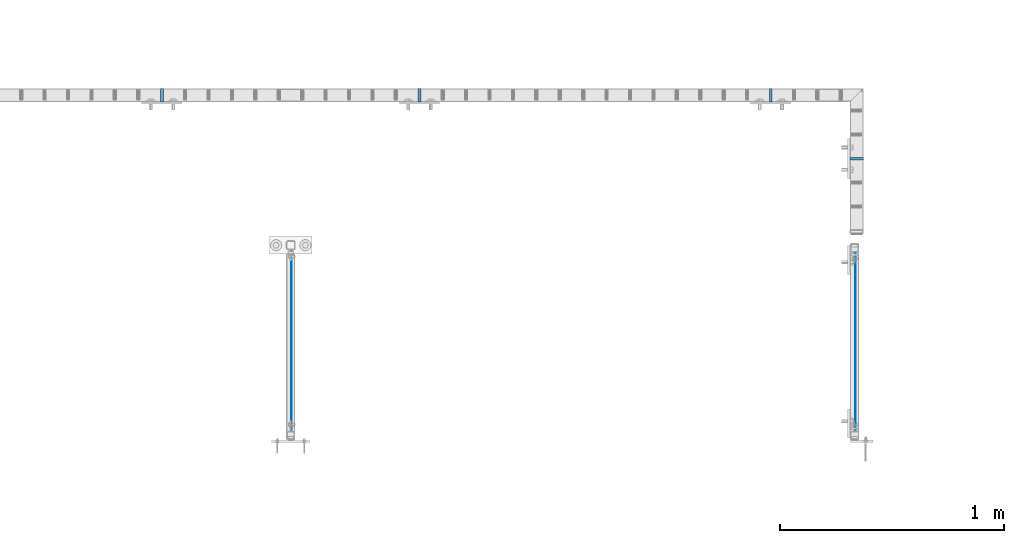
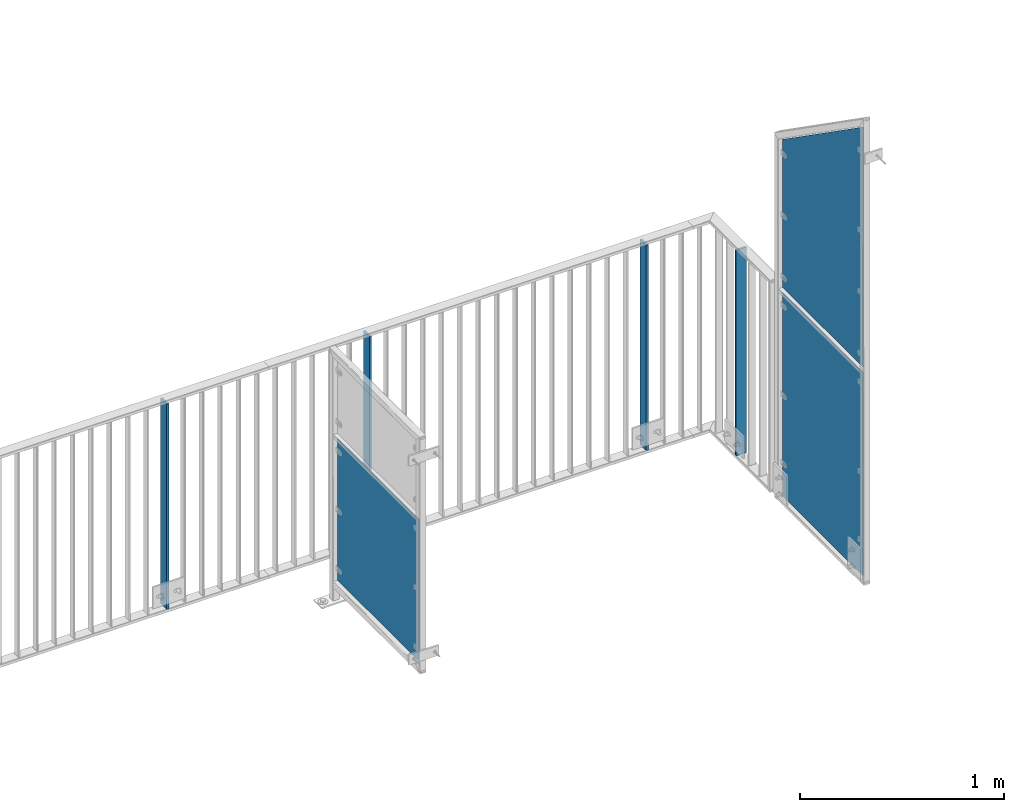
# One storey, part 45 of 156: 7 plates, 6 elements without a shape of their own.
"""IFC2X3 building model written with IfcOpenShell, lengths in millimetres."""

from ifc_helpers import new_model, si_unit, frame, origin_with_axes, origin_2d_with_axis, place, context, subcontext, project, spatial, rectangle, extrude, clip, halfspace, material, type_object, element, aggregate, save


model = new_model("IFC2X3")

# Units and contexts
model_context = context("Model", 3, precision=1e-05, world=origin_with_axes())
body_context = subcontext(model_context, "Body", "Model", "MODEL_VIEW")
ifc_project = project(units=[si_unit("LENGTHUNIT", "METRE", prefix="MILLI"), si_unit("AREAUNIT", "SQUARE_METRE"), si_unit("VOLUMEUNIT", "CUBIC_METRE"), si_unit("MASSUNIT", "GRAM", prefix="KILO"), si_unit("TIMEUNIT", "SECOND"), si_unit("PLANEANGLEUNIT", "RADIAN"), si_unit("SOLIDANGLEUNIT", "STERADIAN"), si_unit("THERMODYNAMICTEMPERATUREUNIT", "DEGREE_CELSIUS"), si_unit("LUMINOUSINTENSITYUNIT", "LUMEN")], contexts=[model_context])

# Site, building, storey
site_placement = place(None, origin_with_axes())
site = spatial("IfcSite", under=ifc_project, at=site_placement, CompositionType="ELEMENT")
building_placement = place(site_placement, origin_with_axes())
building = spatial("IfcBuilding", under=site, at=building_placement, Name="Undefined", CompositionType="ELEMENT")
storey_placement = place(building_placement, origin_with_axes())
storey = spatial("IfcBuildingStorey", under=building, at=storey_placement, Name="Undefined", CompositionType="ELEMENT", Elevation=0.0)

# Assembly, plate
assembly_1_placement = place(storey_placement, origin_with_axes())
assembly_1 = element("IfcElementAssembly", 1, at=assembly_1_placement, inside=storey, AssemblyPlace="NOTDEFINED", PredefinedType="RIGID_FRAME")
ifc_material = material(Name="STEEL/S235JR")
plate_type_1 = type_object("IfcPlateType", PredefinedType="NOTDEFINED")
plate_1_placement = place(assembly_1_placement, frame((34574.6454415188, 21657.9919875293, 3980.00000000003), z_axis=(0.0, -1.0, 0.0), x_axis=(0.0, 0.0, -1.0)))
plate_1 = element("IfcPlate", 2, at=plate_1_placement, type_object=plate_type_1, material=ifc_material, context=body_context, shape_type="SweptSolid", body=[
    extrude(rectangle(XDim=12.0, YDim=60.0, at=origin_2d_with_axis()), frame((1230.0, 0.0, 0.0), z_axis=(-1.0, 0.0, 0.0), x_axis=(0.0, -1.0, 0.0)), (0.0, 0.0, 1.0), 1230.0),
])

assembly_2_placement = place(storey_placement, origin_with_axes())
assembly_2 = element("IfcElementAssembly", 3, at=assembly_2_placement, inside=storey, AssemblyPlace="NOTDEFINED", PredefinedType="RIGID_FRAME")
plate_2_placement = place(assembly_2_placement, frame((33425.3401831972, 21657.9919875293, 3980.00000000003), z_axis=(0.0, -1.0, 0.0), x_axis=(0.0, 0.0, -1.0)))
plate_2 = element("IfcPlate", 4, at=plate_2_placement, type_object=plate_type_1, material=ifc_material, context=body_context, shape_type="SweptSolid", body=[
    extrude(rectangle(XDim=12.0, YDim=60.0, at=origin_2d_with_axis()), frame((1230.0, 0.0, 0.0), z_axis=(-1.0, 0.0, 0.0), x_axis=(0.0, -1.0, 0.0)), (0.0, 0.0, 1.0), 1230.0),
])
aggregate(assembly_2, [plate_2])

assembly_3_placement = place(storey_placement, origin_with_axes())
assembly_3 = element("IfcElementAssembly", 5, at=assembly_3_placement, inside=storey, AssemblyPlace="NOTDEFINED", PredefinedType="RIGID_FRAME")
plate_3_placement = place(assembly_3_placement, frame((36524.9982838167, 21374.1507649875, 3980.00000000003), z_axis=(-1.0, 0.0, 0.0), x_axis=(0.0, 0.0, -1.0)))
plate_3 = element("IfcPlate", 6, at=plate_3_placement, type_object=plate_type_1, material=ifc_material, context=body_context, shape_type="SweptSolid", body=[
    extrude(rectangle(XDim=12.0, YDim=60.0, at=origin_2d_with_axis()), frame((1230.0, 0.0, 0.0), z_axis=(-1.0, 0.0, 0.0), x_axis=(0.0, -1.0, 0.0)), (0.0, 0.0, 1.0), 1230.0),
])
aggregate(assembly_3, [plate_3])

# Plate
plate_4_placement = place(assembly_1_placement, frame((36141.6668934283, 21657.9919875293, 3980.00000000003), z_axis=(0.0, -1.0, 0.0), x_axis=(0.0, 0.0, -1.0)))
plate_4 = element("IfcPlate", 7, at=plate_4_placement, type_object=plate_type_1, material=ifc_material, context=body_context, shape_type="SweptSolid", body=[
    extrude(rectangle(XDim=12.0, YDim=60.0, at=origin_2d_with_axis()), frame((1230.0, 0.0, 0.0), z_axis=(-1.0, 0.0, 0.0), x_axis=(0.0, -1.0, 0.0)), (0.0, 0.0, 1.0), 1230.0),
])

aggregate(assembly_1, [plate_1, plate_4])

# Assembly, plate
assembly_4_placement = place(storey_placement, origin_with_axes())
assembly_4 = element("IfcElementAssembly", 8, at=assembly_4_placement, inside=storey, AssemblyPlace="NOTDEFINED", PredefinedType="RIGID_FRAME")
plate_type_2 = type_object("IfcPlateType", PredefinedType="NOTDEFINED")
plate_5_placement = place(assembly_4_placement, frame((34004.0, 20162.9563390375, 3550.0), z_axis=(0.0, 0.0, 1.0), x_axis=(0.0, 1.0, 0.0)))
plate_5 = element("IfcPlate", 9, at=plate_5_placement, type_object=plate_type_2, material=ifc_material, context=body_context, shape_type="SweptSolid", body=[
    extrude(rectangle(XDim=3.0, YDim=850.0, at=origin_2d_with_axis()), frame((800.050991195178, 0.0, 0.0), z_axis=(-1.0, 0.0, 0.0), x_axis=(0.0, -1.0, 0.0)), (0.0, 0.0, 1.0), 800.05),
])
aggregate(assembly_4, [plate_5])

assembly_5_placement = place(storey_placement, origin_with_axes())
assembly_5 = element("IfcElementAssembly", 10, at=assembly_5_placement, inside=storey, AssemblyPlace="NOTDEFINED", PredefinedType="RIGID_FRAME")
plate_type_3 = type_object("IfcPlateType", PredefinedType="NOTDEFINED")
plate_6_placement = place(assembly_5_placement, frame((36518.9961242676, 20163.0106561273, 3365.0), z_axis=(0.0, 0.0, 1.0), x_axis=(0.0, 1.0, 0.0)))
plate_6 = element("IfcPlate", 11, at=plate_6_placement, type_object=plate_type_3, material=ifc_material, context=body_context, shape_type="SweptSolid", body=[
    extrude(rectangle(XDim=3.0, YDim=1220.0, at=origin_2d_with_axis()), frame((790.000991195178, 0.0, 0.0), z_axis=(-1.0, 0.0, 0.0), x_axis=(0.0, -1.0, 0.0)), (0.0, 0.0, 1.0), 790.0),
])
aggregate(assembly_5, [plate_6])

assembly_6_placement = place(storey_placement, origin_with_axes())
assembly_6 = element("IfcElementAssembly", 12, at=assembly_6_placement, inside=storey, AssemblyPlace="NOTDEFINED", PredefinedType="RIGID_FRAME")
plate_7_placement = place(assembly_6_placement, frame((36518.9961242676, 20163.0037231445, 4730.00076289195), z_axis=(0.0, 0.0, 1.0), x_axis=(0.0, 1.0, 0.0)))
plate_7 = element("IfcPlate", 13, at=plate_7_placement, type_object=plate_type_3, material=ifc_material, context=body_context, shape_type="Clipping", body=[
    clip(extrude(rectangle(XDim=3.0, YDim=1450.0, at=origin_2d_with_axis()), frame((790.000991195178, 0.0, 0.0), z_axis=(-1.0, 0.0, 0.0), x_axis=(0.0, -1.0, 0.0)), (0.0, 0.0, 1.0), 790.0), halfspace(frame((2059.65165642691, -1.5, -729.1), z_axis=(0.573576519196191, 0.0, 0.819151986280191), x_axis=(-0.819151986280191, 0.0, 0.573576519196191)), False)),
])
aggregate(assembly_6, [plate_7])

save(model, "model.ifc")
